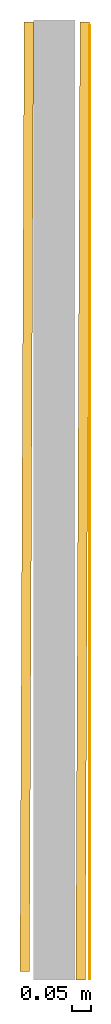
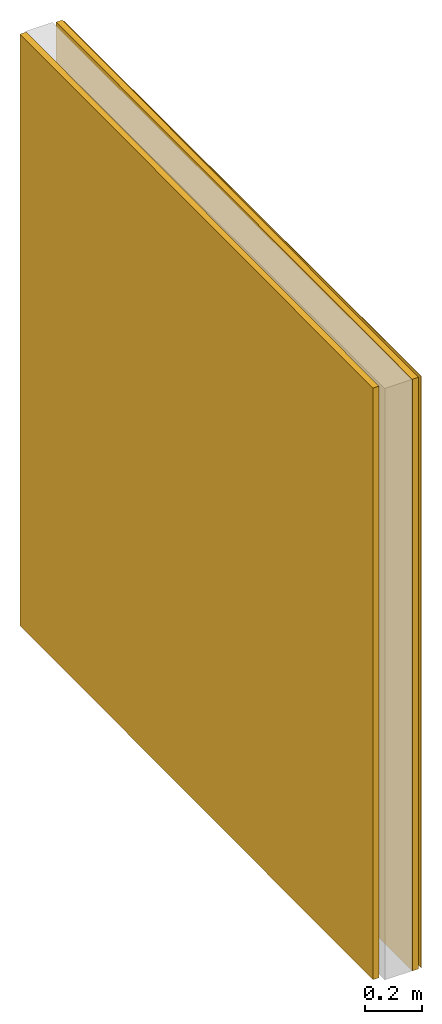
# One storey, part 2 of 2: 3 coverings, 1 opening, 1 element without a shape of its own.
"""IFC4X3_ADD2 building model written with IfcOpenShell, lengths in millimetres."""

from ifc_helpers import new_model, entity, si_unit, converted_unit, direction, frame, origin_with_axes, origin_2d_with_axis, place, context, subcontext, project, spatial, indexed_curve, outline, extrude, clip, halfspace, material, layer, layer_set, layer_usage, type_object, element, aggregate, save


model = new_model("IFC4X3_ADD2")

# Units and contexts
model_context = context("Model", 3, precision=1e-05, world=origin_with_axes(), true_north=direction((0.0, 1.0, 0.0)))
plan_context = context("Plan", 2, precision=1e-05, world=origin_2d_with_axis(), true_north=direction((0.0, 1.0)))
body_context = subcontext(model_context, "Body", "Model", "MODEL_VIEW")
ifc_project = project(units=[si_unit("AREAUNIT", "SQUARE_METRE"), si_unit("VOLUMEUNIT", "CUBIC_METRE"), si_unit("LENGTHUNIT", "METRE", prefix="MILLI"), converted_unit("PLANEANGLEUNIT", "degree", entity("IfcReal", 0.0174532925199433), si_unit("PLANEANGLEUNIT", "RADIAN"), dimensions=[0, 0, 0, 0, 0, 0, 0])], contexts=[model_context, plan_context])

# Site, building, storey
site_placement = place(None, origin_with_axes())
site = spatial("IfcSite", under=ifc_project, at=site_placement)
building_placement = place(site_placement, origin_with_axes())
building = spatial("IfcBuilding", under=site, at=building_placement, Name="Simple 1Bed House")
storey_placement = place(building_placement, origin_with_axes())
storey = spatial("IfcBuildingStorey", under=building, at=storey_placement, Name="Building")

# Coverings
ifc_material_1 = material(Name="25 MPa wooden float", Category="Concrete")
ifc_layer_1 = layer(ifc_material_1, 25.0)
ifc_layer_set_1 = layer_set([ifc_layer_1])
ifc_layer_usage_1 = layer_usage(ifc_layer_set_1, "AXIS2", "POSITIVE", 0.0)
covering_type_1 = type_object("IfcCoveringType", Name="25mm plaster", PredefinedType="CLADDING", material=ifc_layer_set_1)
covering_1_placement = place(storey_placement, frame((2632.72285461426, 6100.70991516113, -1.82032167117541e-12), z_axis=(0.0, 0.0, 1.0), x_axis=(-0.00437846784557142, -0.999990414463721, 0.0)))
element("IfcCovering", 1, at=covering_1_placement, inside=storey, type_object=covering_type_1, material=ifc_layer_usage_1, Name="25mm plaster", context=body_context, shape_type="Clipping", body=[
    clip(extrude(outline(indexed_curve([(0.0, 0.0), (0.0, 25.0), (2643.4910995831, 25.0), (2643.4910995831, 0.0), (0.0, 0.0)], self_intersect=False)), origin_with_axes(), (0.0, 0.0, 1.0), 2550.00019073486), halfspace(frame((2533.49018096924, -2.23517417907715e-05, 1.8201588189269e-12), z_axis=(0.0637502446770668, 0.000279131054412574, 0.0), x_axis=(0.00437846756833666, -0.999990414464935, 0.0)), False)),
])
ifc_layer_usage_2 = layer_usage(ifc_layer_set_1, "AXIS2", "POSITIVE", 0.0)
covering_2_placement = place(storey_placement, frame((2484.96723175049, 6100.70991516113, -1.82032167117541e-12), z_axis=(0.0, 0.0, 1.0), x_axis=(-0.00437846784557142, -0.999990414463721, 0.0)))
element("IfcCovering", 2, at=covering_2_placement, inside=storey, type_object=covering_type_1, material=ifc_layer_usage_2, Name="25mm plaster", context=body_context, shape_type="Clipping", body=[
    clip(extrude(outline(indexed_curve([(0.0, 0.0), (0.0, 25.0), (2535.87583118179, 25.0), (2535.87583118179, 0.0), (0.0, 0.0)], self_intersect=False)), origin_with_axes(), (0.0, 0.0, 1.0), 2550.00019073486), halfspace(frame((2510.8757019043, -9.49949026107788e-05, 1.8201588189269e-12), z_axis=(0.063750647008419, 0.000186720892088488, 0.0), x_axis=(0.00292891288094162, -0.999995710725469, 0.0)), False)),
])

# Assembly, opening, covering
assembly_placement = place(storey_placement, origin_with_axes())
assembly = element("IfcElementAssembly", 3, at=assembly_placement, inside=storey, Name="Default_Name")
opening_placement = place(assembly_placement, frame((2254.96663987611, 3717.2439105808, -0.000119209289550781), z_axis=(0.0, 0.0, 1.0), x_axis=(1.0, 0.0, 0.0)))
element("IfcOpeningElement", 4, at=opening_placement, cuts=assembly, PredefinedType="OPENING", context=body_context, shape_type="SolidModel", body=[
    extrude(outline(indexed_curve([(0.0, 926.298461914062), (499.999877929688, 926.298461914062), (499.999877929688, 0.0), (0.0, 0.0), (0.0, 926.298461914062)])), origin_with_axes(), (0.0, 0.0, 1.0), 2100.00024414062),
])
ifc_material_2 = material(Name="White PVA", Category="Paint")
ifc_layer_2 = layer(ifc_material_2, 2.0)
ifc_layer_set_2 = layer_set([ifc_layer_2])
ifc_layer_usage_3 = layer_usage(ifc_layer_set_2, "AXIS2", "POSITIVE", 0.0)
covering_type_2 = type_object("IfcCoveringType", Name="2 Coat PVA Paint", PredefinedType="CLADDING", material=ifc_layer_set_2)
covering_3_placement = place(assembly_placement, frame((2659.73019599915, 3567.24381446838, -1.82032167117541e-12), z_axis=(0.0, 0.0, 1.0), x_axis=(-6.39757843145941e-07, 0.999999999999795, 0.0)))
covering_3 = element("IfcCovering", 5, at=covering_3_placement, type_object=covering_type_2, material=ifc_layer_usage_3, Name="2Coat Paint", context=body_context, shape_type="SweptSolid", body=[
    extrude(outline(indexed_curve([(0.0, 0.0), (0.0, 2.0), (2525.00030970848, 2.0), (2525.00030970848, 0.0), (0.0, 0.0)], self_intersect=False)), origin_with_axes(), (0.0, 0.0, 1.0), 2550.00019073486),
])
aggregate(assembly, [covering_3])

save(model, "model.ifc")
